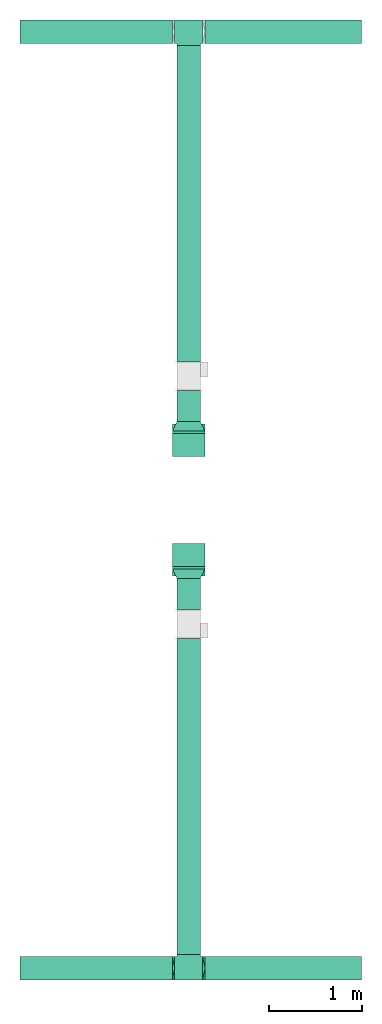
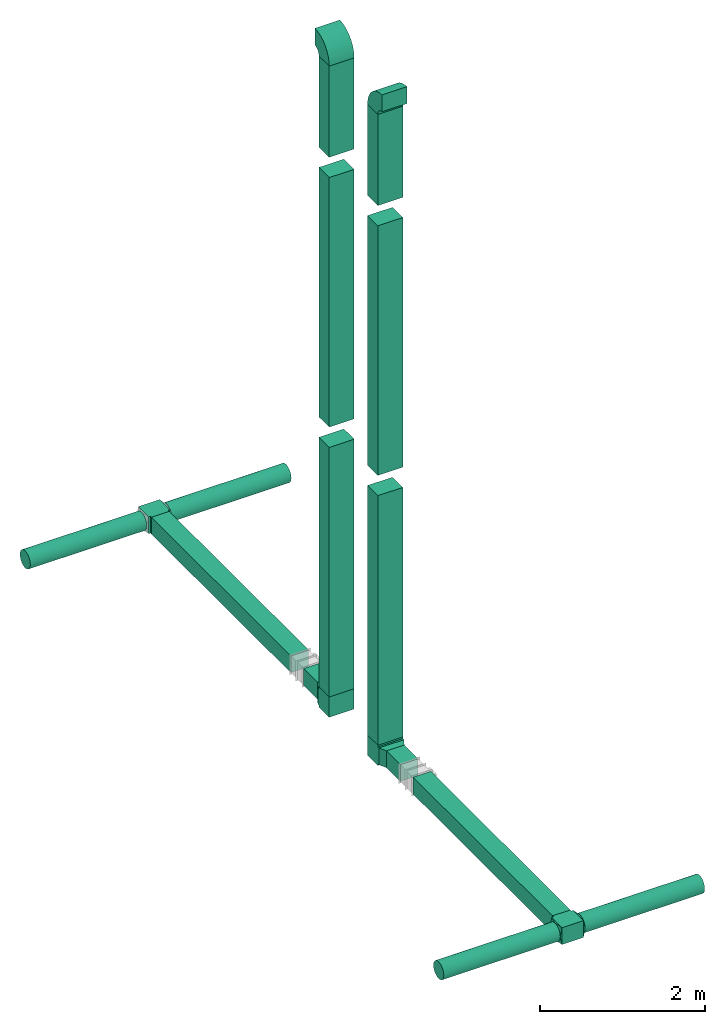
# One storey, part 1 of 3: 14 flow segments, 10 flow fittings.
"""IFC2X3 building model written with IfcOpenShell, lengths in millimetres."""

from ifc_helpers import new_model, entity, si_unit, converted_unit, derived_unit, direction, frame, frame_2d, origin, origin_2d_with_axis, place, context, subcontext, project, spatial, polyline, circle_curve, parameter, trimmed, segment, composite_curve, rectangle, circle, outline, extrude, faceted_brep, source, transform, mapped, material, type_object, type_shapes, element, save


model = new_model("IFC2X3")

# Units and contexts
model_context = context("Model", 3, precision=0.01, world=origin(), true_north=direction((6.12303176911189e-17, 1.0)))
body_context = subcontext(model_context, "Body", "Model", "MODEL_VIEW")
ifc_project = project(units=[si_unit("LENGTHUNIT", "METRE", prefix="MILLI"), si_unit("AREAUNIT", "SQUARE_METRE"), si_unit("VOLUMEUNIT", "CUBIC_METRE"), converted_unit("PLANEANGLEUNIT", "DEGREE", entity("IfcRatioMeasure", 0.0174532925199433), si_unit("PLANEANGLEUNIT", "RADIAN"), dimensions=[0, 0, 0, 0, 0, 0, 0]), si_unit("MASSUNIT", "GRAM", prefix="KILO"), derived_unit("MASSDENSITYUNIT", [(si_unit("MASSUNIT", "GRAM", prefix="KILO"), 1), (si_unit("LENGTHUNIT", "METRE"), -3)]), si_unit("TIMEUNIT", "SECOND"), si_unit("FREQUENCYUNIT", "HERTZ"), si_unit("THERMODYNAMICTEMPERATUREUNIT", "DEGREE_CELSIUS"), derived_unit("THERMALTRANSMITTANCEUNIT", [(si_unit("MASSUNIT", "GRAM", prefix="KILO"), 1), (si_unit("THERMODYNAMICTEMPERATUREUNIT", "KELVIN"), -1), (si_unit("TIMEUNIT", "SECOND"), -3)]), derived_unit("VOLUMETRICFLOWRATEUNIT", [(si_unit("LENGTHUNIT", "METRE"), 3), (si_unit("TIMEUNIT", "SECOND"), -1)]), si_unit("ELECTRICCURRENTUNIT", "AMPERE"), si_unit("ELECTRICVOLTAGEUNIT", "VOLT"), si_unit("POWERUNIT", "WATT"), si_unit("FORCEUNIT", "NEWTON", prefix="KILO"), si_unit("ILLUMINANCEUNIT", "LUX"), si_unit("LUMINOUSFLUXUNIT", "LUMEN"), si_unit("LUMINOUSINTENSITYUNIT", "CANDELA"), derived_unit("USERDEFINED", [(si_unit("MASSUNIT", "GRAM", prefix="KILO"), -1), (si_unit("LENGTHUNIT", "METRE"), -2), (si_unit("TIMEUNIT", "SECOND"), 3), (si_unit("LUMINOUSFLUXUNIT", "LUMEN"), 1)]), derived_unit("LINEARVELOCITYUNIT", [(si_unit("LENGTHUNIT", "METRE"), 1), (si_unit("TIMEUNIT", "SECOND"), -1)]), si_unit("PRESSUREUNIT", "PASCAL"), derived_unit("USERDEFINED", [(si_unit("LENGTHUNIT", "METRE"), -2), (si_unit("MASSUNIT", "GRAM", prefix="KILO"), 1), (si_unit("TIMEUNIT", "SECOND"), -2)])], contexts=[model_context])

# Site, building, storey
site_placement = place(None, origin())
site = spatial("IfcSite", under=ifc_project, at=site_placement, CompositionType="ELEMENT")
building_placement = place(site_placement, origin())
building = spatial("IfcBuilding", under=site, at=building_placement, CompositionType="ELEMENT")
storey_placement = place(building_placement, frame((0.0, 0.0, 4000.0)))
storey = spatial("IfcBuildingStorey", under=building, at=storey_placement, Name="01 Level", CompositionType="ELEMENT", Elevation=4000.0)

# Flow segments
duct_segment_type_1 = type_object("IfcDuctSegmentType", Name="Round Duct:Air", PredefinedType="NOTDEFINED")
flow_segment_1_placement = place(storey_placement, frame((24805.6615179764, -73978.4971681894, 3383.40472776408)))
element("IfcFlowSegment", 1, at=flow_segment_1_placement, inside=storey, type_object=duct_segment_type_1, Name="Round Duct:Air", ObjectType="Round Duct:Air", context=body_context, shape_type="SweptSolid", body=[
    extrude(circle(Radius=125.0, at=origin_2d_with_axis()), frame((0.0, 126.595272235913, 126.595272235916), z_axis=(1.0, 0.0, 0.0), x_axis=(0.0, -1.0, 0.0)), (0.0, 0.0, 1.0), 1675.67988537007),
])
flow_segment_2_placement = place(storey_placement, frame((22822.2515072766, -73978.4971681894, 3383.40472776409)))
element("IfcFlowSegment", 2, at=flow_segment_2_placement, inside=storey, type_object=duct_segment_type_1, Name="Round Duct:Air", ObjectType="Round Duct:Air", context=body_context, shape_type="SweptSolid", body=[
    extrude(circle(Radius=125.0, at=origin_2d_with_axis()), frame((0.0, 126.595272235913, 126.595272235916), z_axis=(1.0, 0.0, 0.0), x_axis=(0.0, -1.0, 0.0)), (0.0, 0.0, 1.0), 1633.4100106998),
])
flow_segment_3_placement = place(storey_placement, frame((24805.6615179764, -63937.1725465623, 3383.40472776408)))
element("IfcFlowSegment", 3, at=flow_segment_3_placement, inside=storey, type_object=duct_segment_type_1, Name="Round Duct:Air", ObjectType="Round Duct:Air", context=body_context, shape_type="SweptSolid", body=[
    extrude(circle(Radius=125.0, at=origin_2d_with_axis()), frame((0.0, 126.595272235922, 126.595272235916), z_axis=(1.0, 0.0, 0.0), x_axis=(0.0, -1.0, 0.0)), (0.0, 0.0, 1.0), 1675.67988537007),
])
flow_segment_4_placement = place(storey_placement, frame((22822.2515072766, -63937.1725465622, 3383.40472776409)))
element("IfcFlowSegment", 4, at=flow_segment_4_placement, inside=storey, type_object=duct_segment_type_1, Name="Round Duct:Air", ObjectType="Round Duct:Air", context=body_context, shape_type="SweptSolid", body=[
    extrude(circle(Radius=125.0, at=origin_2d_with_axis()), frame((0.0, 126.595272235922, 126.595272235916), z_axis=(1.0, 0.0, 0.0), x_axis=(0.0, -1.0, 0.0)), (0.0, 0.0, 1.0), 1633.4100106998),
])
duct_segment_type_2 = type_object("IfcDuctSegmentType", Name="Rectangular Duct:Air", PredefinedType="NOTDEFINED")
flow_segment_5_placement = place(storey_placement, frame((24505.6615179764, -70005.2893332731, 3385.0)))
element("IfcFlowSegment", 5, at=flow_segment_5_placement, inside=storey, type_object=duct_segment_type_2, Name="Rectangular Duct:Air", ObjectType="Rectangular Duct:Air", context=body_context, shape_type="SweptSolid", body=[
    extrude(rectangle(XDim=334.049748133151, YDim=249.999999999999, at=frame_2d((4.33431068813661e-12, 2.16715534406831e-12), x_axis=(1.0, 0.0))), frame((125.0, 167.02487406658, 0.0), z_axis=(0.0, 0.0, 1.0), x_axis=(0.0, 1.0, 0.0)), (0.0, 0.0, 1.0), 249.999999999999),
])
flow_segment_6_placement = place(storey_placement, frame((24505.6615179764, -73701.9018959535, 3385.0)))
element("IfcFlowSegment", 6, at=flow_segment_6_placement, inside=storey, type_object=duct_segment_type_2, Name="Rectangular Duct:Air", ObjectType="Rectangular Duct:Air", context=body_context, shape_type="SweptSolid", body=[
    extrude(rectangle(XDim=3386.61256268045, YDim=249.999999999999, at=frame_2d((4.32009983342141e-12, 0.0), x_axis=(1.0, 0.0))), frame((125.0, 1693.30628134022, 0.0), z_axis=(0.0, 0.0, 1.0), x_axis=(0.0, 1.0, 0.0)), (0.0, 0.0, 1.0), 249.999999999999),
])
flow_segment_7_placement = place(storey_placement, frame((24455.6615179763, -69546.2395851399, 11660.0)))
element("IfcFlowSegment", 7, at=flow_segment_7_placement, inside=storey, type_object=duct_segment_type_2, Name="Rectangular Duct:Air", ObjectType="Rectangular Duct:Air", context=body_context, shape_type="SweptSolid", body=[
    extrude(rectangle(XDim=349.999999999998, YDim=250.000000000004, at=frame_2d((0.0, 4.33431068813661e-12), x_axis=(1.0, 0.0))), frame((175.0, 125.0, 0.0)), (0.0, 0.0, 1.0), 1350.95052634352),
])
flow_segment_8_placement = place(storey_placement, frame((24505.6615179764, -67991.2395851399, 3385.0)))
element("IfcFlowSegment", 8, at=flow_segment_8_placement, inside=storey, type_object=duct_segment_type_2, Name="Rectangular Duct:Air", ObjectType="Rectangular Duct:Air", context=body_context, shape_type="SweptSolid", body=[
    extrude(rectangle(XDim=334.049748133151, YDim=249.999999999999, at=frame_2d((8.66862137627322e-12, 0.0), x_axis=(1.0, 0.0))), frame((125.0, 167.024874066589, 0.0), z_axis=(0.0, 0.0, 1.0), x_axis=(0.0, -1.0, 0.0)), (0.0, 0.0, 1.0), 249.999999999999),
])
flow_segment_9_placement = place(storey_placement, frame((24505.6615179764, -67347.1898370068, 3385.0)))
element("IfcFlowSegment", 9, at=flow_segment_9_placement, inside=storey, type_object=duct_segment_type_2, Name="Rectangular Duct:Air", ObjectType="Rectangular Duct:Air", context=body_context, shape_type="SweptSolid", body=[
    extrude(rectangle(XDim=3386.61256268045, YDim=249.999999999999, at=frame_2d((4.32009983342141e-12, 2.16715534406831e-12), x_axis=(1.0, 0.0))), frame((125.0, 1693.30628134022, 0.0), z_axis=(0.0, 0.0, 1.0), x_axis=(0.0, -1.0, 0.0)), (0.0, 0.0, 1.0), 249.999999999999),
])
flow_segment_10_placement = place(storey_placement, frame((24455.6615179764, -68366.23958514, 11660.0)))
element("IfcFlowSegment", 10, at=flow_segment_10_placement, inside=storey, type_object=duct_segment_type_2, Name="Rectangular Duct:Air", ObjectType="Rectangular Duct:Air", context=body_context, shape_type="SweptSolid", body=[
    extrude(rectangle(XDim=249.999999999995, YDim=349.999999999998, at=frame_2d((4.33431068813661e-12, 0.0), x_axis=(1.0, 0.0))), frame((175.0, 125.0, 0.0), z_axis=(0.0, 0.0, 1.0), x_axis=(0.0, -1.0, 0.0)), (0.0, 0.0, 1.0), 1350.95052634352),
])
for number, where, name in (
    (11, (24455.6615179764, -69546.2395851399, 3660.0), "Rectangular Duct:Air"),
    (12, (24455.6615179764, -69546.2395851399, 7660.0), "Rectangular Duct:Air"),
):
    element("IfcFlowSegment", number, at=place(storey_placement, frame(where)), inside=storey, type_object=duct_segment_type_2, Name=name, ObjectType="Rectangular Duct:Air", context=body_context, shape_type="SweptSolid", body=[
        extrude(rectangle(XDim=249.999999999995, YDim=349.999999999998, at=frame_2d((-4.33431068813661e-12, 0.0), x_axis=(1.0, 0.0))), frame((175.0, 125.0, 0.0), z_axis=(0.0, 0.0, 1.0), x_axis=(0.0, 1.0, 0.0)), (0.0, 0.0, 1.0), 3700.0),
    ])
for number, where, name in (
    (13, (24455.6615179764, -68366.23958514, 3660.0), "Rectangular Duct:Air"),
    (14, (24455.6615179764, -68366.23958514, 7660.0), "Rectangular Duct:Air"),
):
    element("IfcFlowSegment", number, at=place(storey_placement, frame(where)), inside=storey, type_object=duct_segment_type_2, Name=name, ObjectType="Rectangular Duct:Air", context=body_context, shape_type="SweptSolid", body=[
        extrude(rectangle(XDim=249.999999999995, YDim=349.999999999998, at=frame_2d((4.33431068813661e-12, 0.0), x_axis=(1.0, 0.0))), frame((175.0, 125.0, 0.0), z_axis=(0.0, 0.0, 1.0), x_axis=(0.0, -1.0, 0.0)), (0.0, 0.0, 1.0), 3700.0),
    ])

# Flow fittings
duct_fitting_type_1 = type_object("IfcDuctFittingType", Name="Air_Rect", PredefinedType="NOTDEFINED")
shared_shape_1 = source(origin(), body_context, "Body", "SweptSolid", [
    extrude(outline(polyline([(-150.0, 56.2500000000001), (-150.0, -193.75), (150.0, -193.75), (150.0, 56.25), (125.0, 56.25), (125.0, 81.2499999999995), (-125.0, 81.2500000000003), (-125.0, 56.2500000000001), (-150.0, 56.2500000000001)])), frame((0.0, -68.75, -125.0), z_axis=(0.0, 0.0, -1.0), x_axis=(1.0, 0.0, 0.0)), (0.0, 0.0, -1.0), 250.0),
])
type_shapes(duct_fitting_type_1, [shared_shape_1])
flow_fitting_1_placement = place(storey_placement, frame((24630.6615179764, -73851.9018959535, 3510.0), z_axis=(0.0, 0.0, 1.0), x_axis=(-1.0, 0.0, 0.0)))
element("IfcFlowFitting", 15, at=flow_fitting_1_placement, inside=storey, type_object=duct_fitting_type_1, Name="1_001:Air_Rect", ObjectType="1_001:Air_Rect", context=body_context, shape_type="MappedRepresentation", body=[
    mapped(shared_shape_1, transform((0.0, 0.0, 0.0), scale=1.0)),
])
ifc_material_1 = material(Name="Material_Duct")
duct_fitting_type_2 = type_object("IfcDuctFittingType", Name="Air_Multi shape transition_Circ", PredefinedType="NOTDEFINED", material=ifc_material_1)
shared_shape_2 = source(origin(), body_context, "Body", "Brep", [
    faceted_brep([(25.0, -38.627124296869, -118.882064536893), (25.0, -23.8439039196152, -121.223496622539), (25.0, -11.9219519598079, -123.111748311269), (25.0, -5.96097597990422, -124.055874155634), (25.0, 0.0, -125.0), (25.0, 5.9609759747813, -124.055874156445), (25.0, 11.9219519495628, -123.111748312892), (25.0, 23.8439038991258, -121.223496625784), (25.0, 38.6271242968683, -118.882064536893), (25.0, 56.0501404167137, -110.00459441688), (25.0, 73.4731565365591, -101.127124296868), (25.0, 87.3001404167137, -87.3001404167129), (25.0, 101.127124296868, -73.4731565365583), (25.0, 110.004594416881, -56.0501404167129), (25.0, 118.882064536894, -38.6271242968675), (25.0, 121.22349662254, -23.8439039196137), (25.0, 123.11174831127, -11.9219519598064), (25.0, 124.055874155635, -5.96097597990274), (25.0, 125.0, 0.0), (25.0, 124.055874156446, 5.96097597478117), (25.0, 123.111748312892, 11.9219519495627), (25.0, 121.223496625785, 23.8439038991257), (25.0, 118.882064536894, 38.6271242968681), (25.0, 110.004594416881, 56.0501404167135), (25.0, 101.127124296869, 73.4731565365589), (25.0, 87.300140416714, 87.3001404167136), (25.0, 73.4731565365594, 101.127124296868), (25.0, 56.050140416714, 110.004594416881), (25.0, 38.6271242968687, 118.882064536894), (25.0, 23.8439039196148, 121.22349662254), (25.0, 11.9219519598075, 123.11174831127), (25.0, 5.96097597990388, 124.055874155635), (25.0, 0.0, 125.0), (25.0, -5.96097597478126, 124.055874156446), (25.0, -11.9219519495628, 123.111748312892), (25.0, -23.8439038991258, 121.223496625785), (25.0, -38.6271242968682, 118.882064536894), (25.0, -56.0501404167136, 110.004594416881), (25.0, -73.473156536559, 101.127124296869), (25.0, -87.3001404167137, 87.3001404167139), (25.0, -101.127124296868, 73.4731565365593), (25.0, -110.004594416881, 56.0501404167139), (25.0, -118.882064536894, 38.6271242968685), (25.0, -121.22349662254, 23.8439039196147), (25.0, -123.11174831127, 11.9219519598073), (25.0, -124.055874155635, 5.96097597990369), (25.0, -125.0, 0.0), (25.0, -124.055874156446, -5.96097597478013), (25.0, -123.111748312892, -11.9219519495616), (25.0, -121.223496625785, -23.8439038991246), (25.0, -118.882064536894, -38.6271242968671), (25.0, -110.004594416882, -56.0501404167124), (25.0, -101.127124296869, -73.4731565365578), (25.0, -87.3001404167141, -87.3001404167125), (25.0, -73.4731565365595, -101.127124296867), (25.0, -56.0501404167142, -110.00459441688), (0.0, -125.0, 125.0), (0.0, 125.0, 125.0), (0.0, 125.0, -125.0), (0.0, -125.0, -125.0), (13.0142783389037, -59.9286083054818, 125.0), (12.4999999334883, -103.93826768006, 109.288032538106), (3.25356958472593, -108.732152076371, 125.0), (9.76070875417778, -76.1964562291116, 125.0), (6.50713916945186, -92.4643041527413, 125.0), (23.501784792363, -7.49107603818501, 125.0), (22.0035695847259, -14.9821520763703, 125.0), (19.0071391694519, -29.9643041527408, 125.0), (16.0107087541778, -44.9464562291113, 125.0), (6.50713897169544, -125.0, 92.464305141524), (9.76070845754317, -125.0, 76.1964577122852), (13.0142779433909, -125.0, 59.9286102830464), (16.0107084575432, -125.0, 44.9464577122848), (19.0071389716954, -125.0, 29.9643051415232), (22.0035694858477, -125.0, 14.9821525707616), (23.5017847429239, -125.0, 7.49107628538082), (3.25356948584772, -125.0, 108.732152570763), (3.25356958472593, -125.0, -108.73215207637), (6.50713916945185, -125.0, -92.4643041527404), (9.76070875417777, -125.0, -76.1964562291106), (13.0142783389037, -125.0, -59.9286083054808), (16.0107087541778, -125.0, -44.9464562291103), (19.0071391694518, -125.0, -29.9643041527397), (22.0035695847259, -125.0, -14.9821520763692), (23.501784792363, -125.0, -7.4910760381839), (12.4999999334883, -109.288032538106, -103.938267680059), (6.50713897169543, -92.4643051415237, -125.0), (9.76070845754315, -76.196457712285, -125.0), (13.0142779433909, -59.9286102830464, -125.0), (16.0107084575432, -44.9464577122849, -125.0), (19.0071389716954, -29.9643051415235, -125.0), (22.0035694858477, -14.982152570762, -125.0), (23.5017847429239, -7.49107628538127, -125.0), (3.25356948584772, -108.732152570762, -125.0), (3.25356958472593, 108.73215207637, -125.0), (6.50713916945186, 92.4643041527402, -125.0), (9.76070875417778, 76.1964562291106, -125.0), (13.0142783389037, 59.9286083054811, -125.0), (16.0107087541778, 44.9464562291108, -125.0), (19.0071391694519, 29.9643041527404, -125.0), (22.0035695847259, 14.9821520763701, -125.0), (23.501784792363, 7.49107603818496, -125.0), (12.4999999334883, 103.938267680059, -109.288032538105), (6.50713897169544, 125.0, -92.4643051415225), (9.76070845754317, 125.0, -76.1964577122838), (13.0142779433909, 125.0, -59.9286102830451), (16.0107084575432, 125.0, -44.9464577122836), (19.0071389716954, 125.0, -29.9643051415221), (22.0035694858477, 125.0, -14.9821525707606), (23.5017847429239, 125.0, -7.49107628537983), (3.25356948584772, 125.0, -108.732152570761), (3.25356958472593, 125.0, 108.732152076372), (6.50713916945185, 125.0, 92.4643041527418), (9.76070875417778, 125.0, 76.196456229112), (13.0142783389037, 125.0, 59.9286083054821), (16.0107087541778, 125.0, 44.9464562291115), (19.0071391694519, 125.0, 29.9643041527409), (22.0035695847259, 125.0, 14.9821520763703), (23.501784792363, 125.0, 7.49107603818497), (12.4999999334883, 109.288032538105, 103.93826768006), (6.50713897169544, 92.4643051415224, 125.0), (9.76070845754316, 76.1964577122839, 125.0), (13.0142779433909, 59.9286102830454, 125.0), (16.0107084575432, 44.9464577122841, 125.0), (19.0071389716954, 29.9643051415228, 125.0), (22.0035694858477, 14.9821525707615, 125.0), (23.5017847429239, 7.49107628538087, 125.0), (3.25356948584772, 108.732152570761, 125.0)], [[[0, 1, 2, 3, 4, 5, 6, 7, 8, 9, 10, 11, 12, 13, 14, 15, 16, 17, 18, 19, 20, 21, 22, 23, 24, 25, 26, 27, 28, 29, 30, 31, 32, 33, 34, 35, 36, 37, 38, 39, 40, 41, 42, 43, 44, 45, 46, 47, 48, 49, 50, 51, 52, 53, 54, 55]], [[56, 57, 58, 59]], [[60, 37, 36]], [[56, 61, 62]], [[37, 60, 63, 64]], [[65, 66, 67, 68, 60, 36, 35, 34, 33, 32]], [[62, 61, 38]], [[41, 69, 70, 71]], [[64, 38, 37]], [[42, 71, 72, 73, 74, 75, 46, 45, 44, 43]], [[40, 76, 69]], [[71, 42, 41]], [[61, 76, 39]], [[38, 64, 62]], [[76, 40, 39]], [[38, 61, 39]], [[61, 56, 76]], [[69, 41, 40]], [[56, 59, 77, 78, 79, 80, 81, 82, 83, 84, 46, 75, 74, 73, 72, 71, 70, 69, 76]], [[80, 51, 50]], [[59, 85, 77]], [[51, 80, 79, 78]], [[84, 83, 82, 81, 80, 50, 49, 48, 47, 46]], [[77, 85, 52]], [[55, 86, 87, 88]], [[78, 52, 51]], [[0, 88, 89, 90, 91, 92, 4, 3, 2, 1]], [[54, 93, 86]], [[88, 0, 55]], [[85, 93, 53]], [[52, 78, 77]], [[93, 54, 53]], [[52, 85, 53]], [[85, 59, 93]], [[86, 55, 54]], [[92, 91, 90, 89, 88, 87, 86, 93, 59, 58, 94, 95, 96, 97, 98, 99, 100, 101, 4]], [[97, 9, 8]], [[58, 102, 94]], [[9, 97, 96, 95]], [[101, 100, 99, 98, 97, 8, 7, 6, 5, 4]], [[94, 102, 10]], [[13, 103, 104, 105]], [[95, 10, 9]], [[14, 105, 106, 107, 108, 109, 18, 17, 16, 15]], [[12, 110, 103]], [[105, 14, 13]], [[102, 110, 11]], [[10, 95, 94]], [[110, 12, 11]], [[10, 102, 11]], [[102, 58, 110]], [[103, 13, 12]], [[58, 57, 111, 112, 113, 114, 115, 116, 117, 118, 18, 109, 108, 107, 106, 105, 104, 103, 110]], [[114, 23, 22]], [[57, 119, 111]], [[23, 114, 113, 112]], [[118, 117, 116, 115, 114, 22, 21, 20, 19, 18]], [[111, 119, 24]], [[27, 120, 121, 122]], [[112, 24, 23]], [[28, 122, 123, 124, 125, 126, 32, 31, 30, 29]], [[26, 127, 120]], [[122, 28, 27]], [[119, 127, 25]], [[24, 112, 111]], [[127, 26, 25]], [[24, 119, 25]], [[119, 57, 127]], [[120, 27, 26]], [[57, 56, 62, 64, 63, 60, 68, 67, 66, 65, 32, 126, 125, 124, 123, 122, 121, 120, 127]]]),
])
type_shapes(duct_fitting_type_2, [shared_shape_2])
flow_fitting_2_placement = place(storey_placement, frame((24480.6615179764, -73851.9018959535, 3510.0), z_axis=(0.0, 0.0, 1.0), x_axis=(-1.0, 0.0, 0.0)))
element("IfcFlowFitting", 16, at=flow_fitting_2_placement, inside=storey, type_object=duct_fitting_type_2, material=ifc_material_1, Name="multi_shape_trans_001:Air_Multi shape transition_Circ", ObjectType="multi_shape_trans_001:Air_Multi shape transition_Circ", context=body_context, shape_type="MappedRepresentation", body=[
    mapped(shared_shape_2, transform((0.0, 0.0, 0.0), scale=1.0)),
])
flow_fitting_3_placement = place(storey_placement, frame((24780.6615179764, -73851.9018959535, 3510.0)))
element("IfcFlowFitting", 17, at=flow_fitting_3_placement, inside=storey, type_object=duct_fitting_type_2, material=ifc_material_1, Name="multi_shape_trans_001:Air_Multi shape transition_Circ", ObjectType="multi_shape_trans_001:Air_Multi shape transition_Circ", context=body_context, shape_type="MappedRepresentation", body=[
    mapped(shared_shape_2, transform((0.0, 0.0, 0.0), scale=1.0)),
])
duct_fitting_type_3 = type_object("IfcDuctFittingType", Name="Air_Rect", PredefinedType="NOTDEFINED")
shared_shape_3 = source(origin(), body_context, "Body", "SweptSolid", [
    extrude(outline(polyline([(-150.0, 56.2500000000001), (-150.0, -193.75), (150.0, -193.75), (150.0, 56.25), (125.0, 56.25), (125.0, 81.2499999999995), (-125.0, 81.2500000000003), (-125.0, 56.2500000000001), (-150.0, 56.2500000000001)])), frame((0.0, -68.75, -175.0), z_axis=(0.0, 0.0, -1.0), x_axis=(1.0, 0.0, 0.0)), (0.0, 0.0, -1.0), 350.0),
])
type_shapes(duct_fitting_type_3, [shared_shape_3])
flow_fitting_4_placement = place(storey_placement, frame((24630.6615179764, -69421.2395851399, 3510.0), z_axis=(1.0, 0.0, 0.0), x_axis=(0.0, 0.0, -1.0)))
element("IfcFlowFitting", 18, at=flow_fitting_4_placement, inside=storey, type_object=duct_fitting_type_3, Name="1_001:Air_Rect", ObjectType="1_001:Air_Rect", context=body_context, shape_type="MappedRepresentation", body=[
    mapped(shared_shape_3, transform((0.0, 0.0, 0.0), scale=1.0)),
])
ifc_material_2 = material(Name="DF_Material1")
duct_fitting_type_4 = type_object("IfcDuctFittingType", Name="Air_LRD", PredefinedType="NOTDEFINED", material=ifc_material_2)
shared_shape_4 = source(origin(), body_context, "Body", "SweptSolid", [
    extrude(rectangle(XDim=2.0, YDim=350.0, at=origin_2d_with_axis()), frame((99.0, 0.0, -125.0), z_axis=(0.0, 0.0, 1.0), x_axis=(-1.0, 0.0, 0.0)), (0.0, 0.0, 1.0), 250.0),
    extrude(rectangle(XDim=2.0, YDim=250.0, at=origin_2d_with_axis()), frame((1.0, 0.0, -125.0), z_axis=(0.0, 0.0, 1.0), x_axis=(-1.0, 0.0, 0.0)), (0.0, 0.0, 1.0), 250.0),
    extrude(outline(polyline([(11.1803398874972, -134.164078649989), (122.983738762486, -134.164078649988), (-33.5410196624944, 178.885438199985), (-100.623058987489, 89.4427190999923), (11.1803398874972, -134.164078649989)])), frame((50.0, 0.0, -125.0), z_axis=(0.0, 0.0, 1.0), x_axis=(0.894427190999923, -0.447213595499945, 0.0)), (0.0, 0.0, 1.0), 250.0),
])
type_shapes(duct_fitting_type_4, [shared_shape_4])
flow_fitting_5_placement = place(storey_placement, frame((24630.6615179763, -69671.2395851399, 3510.0), z_axis=(0.0, 0.0, 1.0), x_axis=(0.0, 1.0, 0.0)))
element("IfcFlowFitting", 19, at=flow_fitting_5_placement, inside=storey, type_object=duct_fitting_type_4, material=ifc_material_2, Name="LDR:Air", ObjectType="LDR:Air_LRD", context=body_context, shape_type="MappedRepresentation", body=[
    mapped(shared_shape_4, transform((0.0, 0.0, 0.0), scale=1.0)),
])
duct_fitting_type_5 = type_object("IfcDuctFittingType", Name="Air_Rect", PredefinedType="NOTDEFINED")
shared_shape_5 = source(origin(), body_context, "Body", "SweptSolid", [
    extrude(outline(polyline([(-56.2499999999996, -150.0), (193.75, -150.0), (193.75, 150.0), (-56.2500000000005, 150.0), (-56.2500000000004, 125.0), (-81.2499999999999, 125.0), (-81.2499999999999, -125.0), (-56.2499999999996, -125.0), (-56.2499999999996, -150.0)])), frame((0.0, 68.75, -125.0), z_axis=(0.0, 0.0, 1.0), x_axis=(0.0, -1.0, 0.0)), (0.0, 0.0, 1.0), 250.0),
])
type_shapes(duct_fitting_type_5, [shared_shape_5])
flow_fitting_6_placement = place(storey_placement, frame((24630.6615179764, -63810.5772743263, 3510.0), z_axis=(0.0, 0.0, 1.0), x_axis=(-1.0, 0.0, 0.0)))
element("IfcFlowFitting", 20, at=flow_fitting_6_placement, inside=storey, type_object=duct_fitting_type_5, Name="1_001:Air_Rect", ObjectType="1_001:Air_Rect", context=body_context, shape_type="MappedRepresentation", body=[
    mapped(shared_shape_5, transform((0.0, 0.0, 0.0), scale=1.0)),
])
duct_fitting_type_6 = type_object("IfcDuctFittingType", Name="Air_Rect", PredefinedType="NOTDEFINED")
shared_shape_6 = source(origin(), body_context, "Body", "SweptSolid", [
    extrude(outline(polyline([(-56.2499999999996, -150.0), (193.75, -150.0), (193.75, 150.0), (-56.2500000000005, 150.0), (-56.2500000000004, 125.0), (-81.2499999999999, 125.0), (-81.2499999999999, -125.0), (-56.2499999999996, -125.0), (-56.2499999999996, -150.0)])), frame((0.0, 68.75, -175.0), z_axis=(0.0, 0.0, 1.0), x_axis=(0.0, -1.0, 0.0)), (0.0, 0.0, 1.0), 350.0),
])
type_shapes(duct_fitting_type_6, [shared_shape_6])
flow_fitting_7_placement = place(storey_placement, frame((24630.6615179764, -68241.2395851399, 3510.0), z_axis=(1.0, 0.0, 0.0), x_axis=(0.0, 0.0, -1.0)))
element("IfcFlowFitting", 21, at=flow_fitting_7_placement, inside=storey, type_object=duct_fitting_type_6, Name="1_001:Air_Rect", ObjectType="1_001:Air_Rect", context=body_context, shape_type="MappedRepresentation", body=[
    mapped(shared_shape_6, transform((0.0, 0.0, 0.0), scale=1.0)),
])
duct_fitting_type_7 = type_object("IfcDuctFittingType", Name="Air_LRD", PredefinedType="NOTDEFINED", material=ifc_material_2)
shared_shape_7 = source(origin(), body_context, "Body", "SweptSolid", [
    extrude(rectangle(XDim=350.0, YDim=2.0, at=origin_2d_with_axis()), frame((99.0, 0.0, -125.0), z_axis=(0.0, 0.0, 1.0), x_axis=(0.0, 1.0, 0.0)), (0.0, 0.0, 1.0), 250.0),
    extrude(rectangle(XDim=250.0, YDim=2.0, at=origin_2d_with_axis()), frame((1.0, 0.0, -125.0), z_axis=(0.0, 0.0, 1.0), x_axis=(0.0, 1.0, 0.0)), (0.0, 0.0, 1.0), 250.0),
    extrude(outline(polyline([(-125.0, -50.0), (125.0, -50.0), (175.0, 50.0), (-175.0, 50.0), (-125.0, -50.0)])), frame((50.0, 0.0, -125.0), z_axis=(0.0, 0.0, 1.0), x_axis=(0.0, -1.0, 0.0)), (0.0, 0.0, 1.0), 250.0),
])
type_shapes(duct_fitting_type_7, [shared_shape_7])
flow_fitting_8_placement = place(storey_placement, frame((24630.6615179763, -67991.2395851399, 3510.0), z_axis=(0.0, 0.0, 1.0), x_axis=(0.0, -1.0, 0.0)))
element("IfcFlowFitting", 22, at=flow_fitting_8_placement, inside=storey, type_object=duct_fitting_type_7, material=ifc_material_2, Name="LDR:Air", ObjectType="LDR:Air_LRD", context=body_context, shape_type="MappedRepresentation", body=[
    mapped(shared_shape_7, transform((0.0, 0.0, 0.0), scale=1.0)),
])
duct_fitting_type_8 = type_object("IfcDuctFittingType", Name="Air_Elbow_Rect", PredefinedType="NOTDEFINED")
shared_shape_8 = source(origin(), body_context, "Body", "SweptSolid", [
    extrude(outline(composite_curve([segment(polyline([(-237.5, -112.5), (12.5, -112.5)]), True, "CONTINUOUS"), segment(trimmed(circle_curve(frame_2d((112.5, -112.5), x_axis=(0.0, 1.0)), 100.0), [parameter(0.0)], [parameter(90.0000000000001)], True, "PARAMETER"), False, "CONTINUOUS"), segment(polyline([(112.5, -12.4999999999998), (112.5, 237.5)]), True, "CONTINUOUS"), segment(trimmed(circle_curve(frame_2d((112.5, -112.5), x_axis=(0.0, 1.0)), 350.0), [parameter(0.0)], [parameter(90.0000000000001)], True, "PARAMETER"), True, "CONTINUOUS")], self_intersect=False)), frame((-112.499999999999, 112.5, -175.0), z_axis=(0.0, 0.0, 1.0), x_axis=(-1.0, 0.0, 0.0)), (0.0, 0.0, 1.0), 350.0),
])
type_shapes(duct_fitting_type_8, [shared_shape_8])
for number, where, z_axis, x_axis, name in (
    (23, (24630.6615179763, -69421.2395851399, 13235.9505263435), (1.0, 0.0, 0.0), (0.0, 0.0, 1.0), "elbow1_001:Air_Elbow_Rect"),
    (24, (24630.6615179764, -68241.2395851399, 13235.9505263435), (-1.0, 0.0, 0.0), (0.0, 0.0, 1.0), "elbow1_001:Air_Elbow_Rect"),
):
    element("IfcFlowFitting", number, at=place(storey_placement, frame(where, z_axis=z_axis, x_axis=x_axis)), inside=storey, type_object=duct_fitting_type_8, Name=name, ObjectType="elbow1_001:Air_Elbow_Rect", context=body_context, shape_type="MappedRepresentation", body=[
        mapped(shared_shape_8, transform((0.0, 0.0, 0.0), scale=1.0)),
    ])

save(model, "model.ifc")
